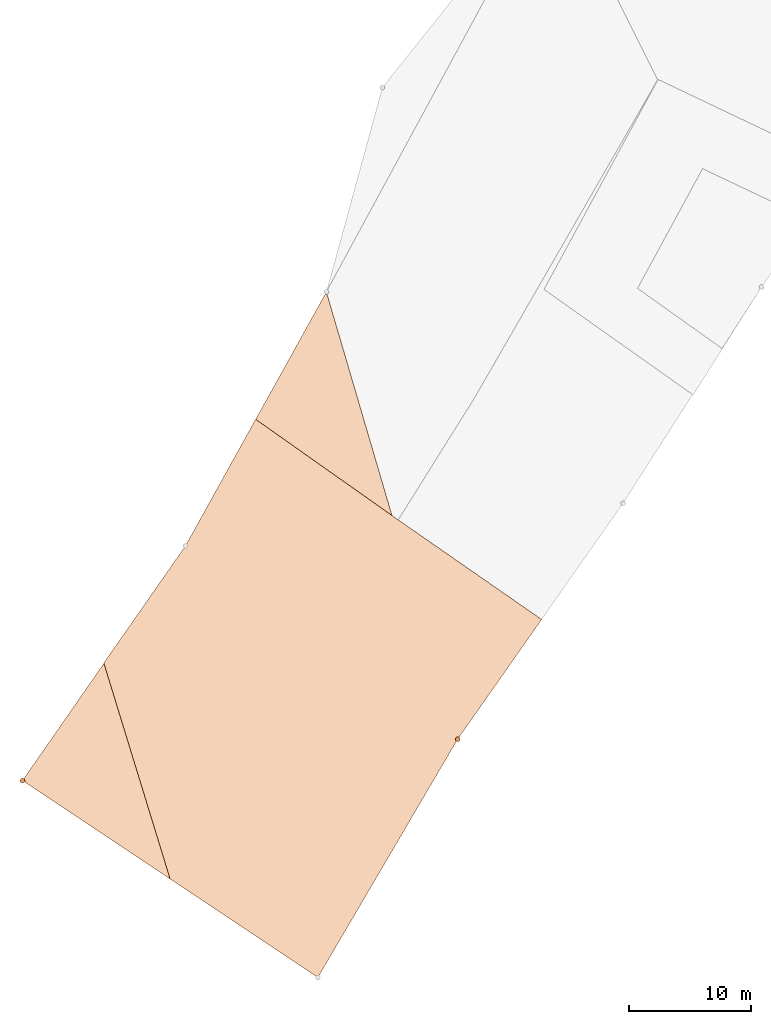
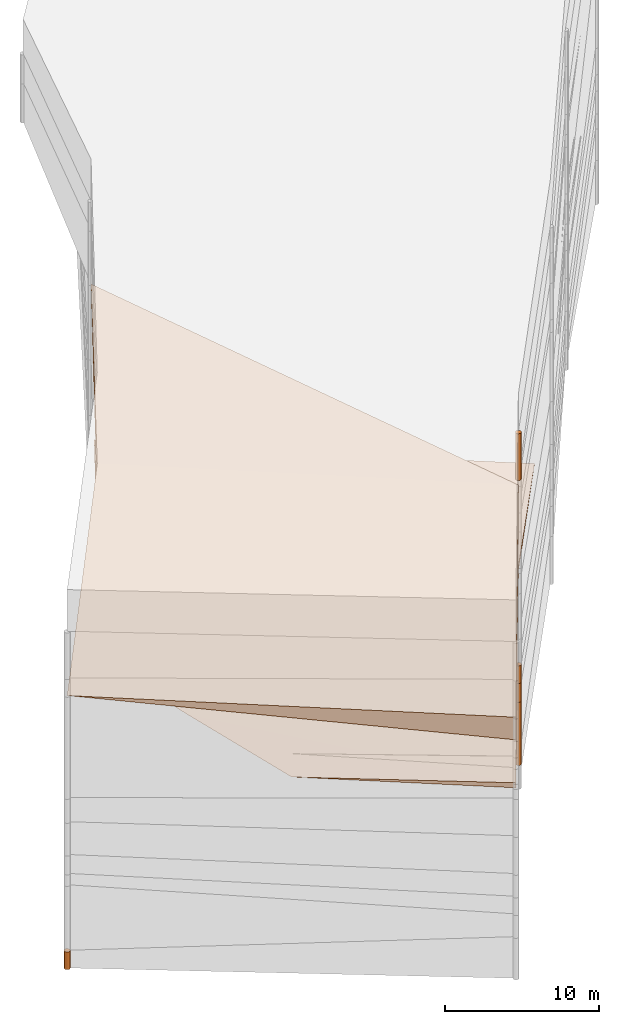
# One storey, part 5 of 24: 7 geographic elements.
"""IFC4 building model written with IfcOpenShell, lengths in metres."""

import ifcopenshell
import ifcopenshell.guid

model = None  # the IFC model being written
_history = None  # IfcOwnerHistory: only IFC2X3 demands one
_inside = {}  # id of a spatial element -> (the spatial element, [elements in it])
_under = {}  # id of a project, library or spatial element -> (it, [spatial elements below it])
_declared = {}  # id of a project -> (the project, [libraries it declares])
_typed = {}  # id of a type object -> (the type object, [elements of that type])
_made_of = {}  # id of a material, layer set ... -> (it, [elements and type objects made of it])


def new_model(schema):
    """Start an empty IFC model of exactly this schema.

    Asked for "IFC4X3", IfcOpenShell would pick the latest addendum, in which some entities
    have other attributes; the version numbers below select the first issue.
    IFC2X3 requires an IfcOwnerHistory on every rooted entity: one is made here for all.
    """
    global model, _history
    if schema == "IFC4X3":
        model = ifcopenshell.file(schema_version=(4, 3, 0, 0))
    else:
        model = ifcopenshell.file(schema=schema)
    _inside.clear()
    _under.clear()
    _declared.clear()
    _typed.clear()
    _made_of.clear()
    _history = None
    if model.schema == "IFC2X3":
        org = make("IfcOrganization", Name="unknown")
        user = make(
            "IfcPersonAndOrganization",
            ThePerson=make("IfcPerson", FamilyName="unknown"),
            TheOrganization=org,
        )
        app = make(
            "IfcApplication",
            ApplicationDeveloper=org,
            Version="unknown",
            ApplicationFullName="unknown",
            ApplicationIdentifier="unknown",
        )
        _history = make(
            "IfcOwnerHistory",
            OwningUser=user,
            OwningApplication=app,
            ChangeAction="ADDED",
            CreationDate=0,
        )
    return model


def make(cls, **values):
    """One entity of the class cls with the attributes given. An attribute that is None is left unset."""
    return model.create_entity(
        cls, **{name: value for name, value in values.items() if value is not None}
    )


def entity(cls, *values):
    """Any entity or typed value of the class cls, its attributes in the order of the schema. None: left unset."""
    e = model.create_entity(cls)
    for i, value in enumerate(values):
        if value is not None:
            e[i] = value
    return e


def rooted(cls, **values):
    """An entity with a GlobalId (a new one), such as an element, a storey or a relation."""
    return make(cls, GlobalId=ifcopenshell.guid.new(), OwnerHistory=_history, **values)


def si_unit(unit_type, name, prefix=None):
    """IfcSIUnit, for example si_unit("LENGTHUNIT", "METRE", prefix="MILLI")."""
    return make("IfcSIUnit", UnitType=unit_type, Prefix=prefix, Name=name)


def converted_unit(unit_type, name, factor, base, dimensions=None, offset=None):
    """IfcConversionBasedUnit, such as the inch: factor (a typed value) times the base unit."""
    return make(
        "IfcConversionBasedUnit"
        if offset is None
        else "IfcConversionBasedUnitWithOffset",
        ConversionOffset=offset,
        Dimensions=None
        if dimensions is None
        else entity("IfcDimensionalExponents", *dimensions),
        UnitType=unit_type,
        Name=name,
        ConversionFactor=make(
            "IfcMeasureWithUnit", ValueComponent=factor, UnitComponent=base
        ),
    )


def assignment(units):
    """IfcUnitAssignment: the units of a project."""
    return None if units is None else make("IfcUnitAssignment", Units=units)


def point(xyz):
    """IfcCartesianPoint."""
    return None if xyz is None else make("IfcCartesianPoint", Coordinates=xyz)


def direction(xyz):
    """IfcDirection."""
    return None if xyz is None else make("IfcDirection", DirectionRatios=xyz)


def frame(location, z_axis=None, x_axis=None):
    """IfcAxis2Placement3D, a coordinate frame: its origin and axes. An axis left out is left unset."""
    return make(
        "IfcAxis2Placement3D",
        Location=point(location),
        Axis=direction(z_axis),
        RefDirection=direction(x_axis),
    )


def frame_2d(location, x_axis=None):
    """IfcAxis2Placement2D, a coordinate frame in the plane: its origin and x axis."""
    return make(
        "IfcAxis2Placement2D", Location=point(location), RefDirection=direction(x_axis)
    )


def origin_with_axes():
    """The frame at (0, 0, 0) with the z axis (0, 0, 1) and the x axis (1, 0, 0) written out."""
    return frame((0.0, 0.0, 0.0), z_axis=(0.0, 0.0, 1.0), x_axis=(1.0, 0.0, 0.0))


def origin_2d_with_axis():
    """The frame at (0, 0) in the plane with the x axis (1, 0) written out."""
    return frame_2d((0.0, 0.0), x_axis=(1.0, 0.0))


def place(relative_to, where):
    """IfcLocalPlacement: puts the frame where relative to a parent placement (None: the world)."""
    return make(
        "IfcLocalPlacement", PlacementRelTo=relative_to, RelativePlacement=where
    )


def context(
    kind, dimensions, precision=None, world=None, true_north=None, identifier=None
):
    """IfcGeometricRepresentationContext, for example the 3D "Model" context."""
    return make(
        "IfcGeometricRepresentationContext",
        ContextIdentifier=identifier,
        ContextType=kind,
        CoordinateSpaceDimension=dimensions,
        Precision=precision,
        WorldCoordinateSystem=world,
        TrueNorth=true_north,
    )


def subcontext(parent, identifier, kind, view, scale=None):
    """IfcGeometricRepresentationSubContext, for example "Body" below "Model"."""
    return make(
        "IfcGeometricRepresentationSubContext",
        ContextIdentifier=identifier,
        ContextType=kind,
        ParentContext=parent,
        TargetScale=scale,
        TargetView=view,
    )


def project(units=None, contexts=None):
    """IfcProject with its units and contexts."""
    return rooted(
        "IfcProject",
        Name="project",
        RepresentationContexts=contexts,
        UnitsInContext=assignment(units),
    )


def spatial(cls, under=None, at=None, **own):
    """A site, building, storey or space (cls), placed at a placement, below another one or the project."""
    s = rooted(cls, ObjectPlacement=at, **own)
    if under is not None:
        _under.setdefault(under.id(), (under, []))[1].append(s)
    return s


def point_list(points):
    """IfcCartesianPointList2D or 3D."""
    cls = (
        "IfcCartesianPointList2D" if len(points[0]) == 2 else "IfcCartesianPointList3D"
    )
    return make(cls, CoordList=points)


def polygons(points, faces, closed=None, point_numbers=None):
    """IfcPolygonalFaceSet: a face is its outer loop, then its inner loops; points numbered from 1."""
    made = []
    for loops in faces:
        if len(loops) == 1:
            made.append(make("IfcIndexedPolygonalFace", CoordIndex=loops[0]))
        else:
            made.append(
                make(
                    "IfcIndexedPolygonalFaceWithVoids",
                    CoordIndex=loops[0],
                    InnerCoordIndices=loops[1:],
                )
            )
    return make(
        "IfcPolygonalFaceSet",
        Coordinates=point_list(points),
        Closed=closed,
        Faces=made,
        PnIndex=point_numbers,
    )


def shape(context_of_items, identifier, shape_type, items):
    """IfcShapeRepresentation: the items that make up one representation, for example the "Body"."""
    return make(
        "IfcShapeRepresentation",
        ContextOfItems=context_of_items,
        RepresentationIdentifier=identifier,
        RepresentationType=shape_type,
        Items=items,
    )


def made_of(thing, what):
    """Note that an element or type object is made of a material, layer set ...; save() writes the relation."""
    if what is not None:
        _made_of.setdefault(what.id(), (what, []))[1].append(thing)
    return thing


def element(
    cls,
    number,
    at=None,
    inside=None,
    cuts=None,
    type_object=None,
    material=None,
    context=None,
    identifier="Body",
    shape_type=None,
    held_by="IfcProductDefinitionShape",
    body=None,
    shapes=None,
    **own,
):
    """One element of the class cls, such as IfcWall. Its Tag is "e" and its number.

    at: its placement. inside: the storey or other place that contains it. cuts: it is an
    opening in that element (IfcRelVoidsElement). A single representation is given by context,
    identifier, shape_type and body (its items); several are given by shapes. held_by: the class
    of the entity that holds the representations. save() writes the other relations.
    """
    e = rooted(cls, Tag="e%d" % number, ObjectPlacement=at, **own)
    if body is not None:
        shapes = [shape(context, identifier, shape_type, body)]
    if shapes is not None:
        e.Representation = make(held_by, Representations=shapes)
    if inside is not None:
        _inside.setdefault(inside.id(), (inside, []))[1].append(e)
    if cuts is not None:
        rooted(
            "IfcRelVoidsElement", RelatingBuildingElement=cuts, RelatedOpeningElement=e
        )
    if type_object is not None:
        _typed.setdefault(type_object.id(), (type_object, []))[1].append(e)
    return made_of(e, material)


def aggregate(whole, parts):
    """IfcRelAggregates: a whole, such as a stair, and the parts it consists of."""
    return rooted("IfcRelAggregates", RelatingObject=whole, RelatedObjects=parts)


def save(model, path):
    """Write the relations noted so far, then the file.

    IfcRelAggregates (storeys below a building ...), IfcRelContainedInSpatialStructure (elements
    in a storey), IfcRelDefinesByType, IfcRelAssociatesMaterial and IfcRelDeclares: one each for
    every whole, place, type object, material and project.
    """
    for whole, parts in _under.values():
        aggregate(whole, parts)
    for where, things in _inside.values():
        rooted(
            "IfcRelContainedInSpatialStructure",
            RelatedElements=things,
            RelatingStructure=where,
        )
    for kind, things in _typed.values():
        rooted("IfcRelDefinesByType", RelatedObjects=things, RelatingType=kind)
    for what, things in _made_of.values():
        rooted("IfcRelAssociatesMaterial", RelatedObjects=things, RelatingMaterial=what)
    for by, libraries in _declared.values():
        rooted("IfcRelDeclares", RelatingContext=by, RelatedDefinitions=libraries)
    model.write(path)


model = new_model("IFC4")

# Units and contexts
model_context = context("Model", 3, precision=1e-05, world=origin_with_axes())
plan_context = context("Plan", 2, precision=1e-05, world=origin_2d_with_axis())
body_context = subcontext(model_context, "Body", "Model", "MODEL_VIEW")
ifc_project = project(units=[converted_unit("PLANEANGLEUNIT", "degree", entity("IfcReal", 0.0174532925199433), si_unit("PLANEANGLEUNIT", "RADIAN"), dimensions=[0, 0, 0, 0, 0, 0, 0]), si_unit("AREAUNIT", "SQUARE_METRE"), si_unit("VOLUMEUNIT", "CUBIC_METRE"), si_unit("LENGTHUNIT", "METRE")], contexts=[model_context, plan_context])

# Site, building, storey
site_placement = place(None, origin_with_axes())
site = spatial("IfcSite", under=ifc_project, at=site_placement)
building_placement = place(site_placement, origin_with_axes())
building = spatial("IfcBuilding", under=site, at=building_placement, Name="Building")
storey_placement = place(building_placement, origin_with_axes())
storey = spatial("IfcBuildingStorey", under=building, at=storey_placement, Name="Storey")

# Geographic elements
geographic_element_1_placement = place(storey_placement, frame((-2.0654125213623, 16.8077659606934, 12.5232429504395), z_axis=(0.0, 0.0, 1.0), x_axis=(0.813539034007344, -0.58151030957877, 0.0)))
element("IfcGeographicElement", 1, at=geographic_element_1_placement, inside=storey, PredefinedType="NOTDEFINED", context=body_context, shape_type="Tessellation", body=[
    polygons([(-20.7735157012939, 33.8179397583008, -3.01824259757996), (-18.0570030212402, 10.0694561004639, -4.22324371337891), (-18.0570049285889, 10.0694599151611, -0.523242890834808), (11.4541826248169, -12.4727153778076, -4.72324132919312), (9.41227912902832, 10.1600189208984, -0.423243492841721), (11.4541816711426, -12.4727153778076, -2.92324137687683), (-17.7352809906006, -13.4240798950195, -2.52324271202087)], [[[3, 1, 2]], [[5, 6, 4]], [[7, 4, 6]], [[2, 5, 7]], [[7, 6, 5]], [[1, 3, 5]], [[1, 5, 2]], [[7, 3, 2]], [[7, 5, 4]], [[3, 7, 5]]]),
])
geographic_element_2_placement = place(storey_placement, frame((-4.35113143920898, 15.1479167938232, 4.93172883987427), z_axis=(0.0, 0.0, 1.0), x_axis=(0.768162961571184, -0.640254374815344, 0.0)))
element("IfcGeographicElement", 2, at=geographic_element_2_placement, inside=storey, PredefinedType="NOTDEFINED", context=body_context, shape_type="Tessellation", body=[
    polygons([(-9.25384426116943, -5.33445310592651, -0.181728839874268), (-18.061107635498, 11.4407739639282, 0.16827104985714), (-18.061107635498, 11.4407739639282, 1.06827068328857), (9.32578659057617, 13.5686807632446, 0.268270462751389), (9.32578659057617, 13.5686807632446, 0.668270587921143), (13.0408973693848, -8.8502368927002, -0.931725978851318), (13.0408973693848, -8.8502368927002, -0.5317263007164), (-1.47834300994873, -10.4072074890137, -0.731728553771973), (-6.60297393798828, 24.2455081939697, 0.468271255493164), (8.32325649261475, 25.55983543396, 0.468271523714066), (-20.2963562011719, 23.1440601348877, 0.618271589279175), (-17.0553722381592, -0.243257105350494, 0.618271350860596)], [[[3, 2, 12]], [[7, 4, 5]], [[1, 5, 3]], [[7, 1, 8]], [[4, 1, 2]], [[3, 9, 11]], [[1, 6, 8]], [[6, 7, 8]], [[4, 9, 10]], [[5, 4, 10]], [[5, 9, 3]], [[9, 2, 11]], [[2, 3, 11]], [[1, 3, 12]], [[2, 1, 12]], [[7, 6, 4]], [[1, 7, 5]], [[4, 6, 1]], [[4, 2, 9]], [[5, 10, 9]]]),
])
geographic_element_3_placement = place(storey_placement, frame((11.5, 19.6000003814697, 14.4499998092651), z_axis=(0.0, 0.0, 1.0), x_axis=(1.0, 0.0, 0.0)))
element("IfcGeographicElement", 3, at=geographic_element_3_placement, inside=storey, PredefinedType="NOTDEFINED", context=body_context, shape_type="Tessellation", body=[
    polygons([(0.0, 0.0, -1.84999990463257), (0.0390180610120296, 0.196157038211823, -1.84999990463257), (0.0, 0.199999988079071, -1.84999990463257), (0.0, 0.0, 1.84999990463257), (0.0, 0.199999988079071, 1.84999990463257), (0.0390180610120296, 0.196157038211823, 1.84999990463257), (0.0765366926789284, 0.18477588891983, -1.84999990463257), (0.0765366926789284, 0.18477588891983, 1.84999990463257), (0.111114047467709, 0.166293919086456, -1.84999990463257), (0.111114047467709, 0.166293919086456, 1.84999990463257), (0.141421362757683, 0.141421362757683, -1.84999990463257), (0.141421362757683, 0.141421362757683, 1.84999990463257), (0.166293919086456, 0.111114047467709, -1.84999990463257), (0.166293919086456, 0.111114047467709, 1.84999990463257), (0.18477588891983, 0.0765366926789284, -1.84999990463257), (0.18477588891983, 0.0765366926789284, 1.84999990463257), (0.196157038211823, 0.0390180610120296, -1.84999990463257), (0.196157038211823, 0.0390180610120296, 1.84999990463257), (0.199999988079071, 0.0, -1.84999990463257), (0.199999988079071, 0.0, 1.84999990463257), (0.196157038211823, -0.0390180610120296, -1.84999990463257), (0.196157038211823, -0.0390180610120296, 1.84999990463257), (0.18477588891983, -0.0765366926789284, -1.84999990463257), (0.18477588891983, -0.0765366926789284, 1.84999990463257), (0.166293919086456, -0.111114047467709, -1.84999990463257), (0.166293919086456, -0.111114047467709, 1.84999990463257), (0.141421362757683, -0.141421362757683, -1.84999990463257), (0.141421362757683, -0.141421362757683, 1.84999990463257), (0.111114047467709, -0.166293919086456, -1.84999990463257), (0.111114047467709, -0.166293919086456, 1.84999990463257), (0.0765366926789284, -0.18477588891983, -1.84999990463257), (0.0765366926789284, -0.18477588891983, 1.84999990463257), (0.0390180610120296, -0.196157038211823, -1.84999990463257), (0.0390180610120296, -0.196157038211823, 1.84999990463257), (0.0, -0.199999988079071, -1.84999990463257), (0.0, -0.199999988079071, 1.84999990463257), (-0.0390180610120296, -0.196157038211823, -1.84999990463257), (-0.0390180610120296, -0.196157038211823, 1.84999990463257), (-0.0765366926789284, -0.18477588891983, -1.84999990463257), (-0.0765366926789284, -0.18477588891983, 1.84999990463257), (-0.111114047467709, -0.166293919086456, -1.84999990463257), (-0.111114047467709, -0.166293919086456, 1.84999990463257), (-0.141421362757683, -0.141421362757683, -1.84999990463257), (-0.141421362757683, -0.141421362757683, 1.84999990463257), (-0.166293919086456, -0.111114047467709, -1.84999990463257), (-0.166293919086456, -0.111114047467709, 1.84999990463257), (-0.18477588891983, -0.0765366926789284, -1.84999990463257), (-0.18477588891983, -0.0765366926789284, 1.84999990463257), (-0.196157038211823, -0.0390180610120296, -1.84999990463257), (-0.196157038211823, -0.0390180610120296, 1.84999990463257), (-0.199999988079071, 0.0, -1.84999990463257), (-0.199999988079071, 0.0, 1.84999990463257), (-0.196157038211823, 0.0390180610120296, -1.84999990463257), (-0.196157038211823, 0.0390180610120296, 1.84999990463257), (-0.18477588891983, 0.0765366926789284, -1.84999990463257), (-0.18477588891983, 0.0765366926789284, 1.84999990463257), (-0.166293919086456, 0.111114047467709, -1.84999990463257), (-0.166293919086456, 0.111114047467709, 1.84999990463257), (-0.141421362757683, 0.141421362757683, -1.84999990463257), (-0.141421362757683, 0.141421362757683, 1.84999990463257), (-0.111114047467709, 0.166293919086456, -1.84999990463257), (-0.111114047467709, 0.166293919086456, 1.84999990463257), (-0.0765366926789284, 0.18477588891983, -1.84999990463257), (-0.0765366926789284, 0.18477588891983, 1.84999990463257), (-0.0390180610120296, 0.196157038211823, -1.84999990463257), (-0.0390180610120296, 0.196157038211823, 1.84999990463257)], [[[3, 2, 1]], [[6, 5, 4]], [[62, 64, 63, 61]], [[2, 7, 1]], [[8, 6, 4]], [[30, 32, 31, 29]], [[7, 9, 1]], [[10, 8, 4]], [[10, 12, 11, 9]], [[9, 11, 1]], [[12, 10, 4]], [[11, 13, 1]], [[12, 4, 14]], [[66, 5, 3, 65]], [[1, 13, 15]], [[4, 16, 14]], [[42, 44, 43, 41]], [[1, 15, 17]], [[4, 18, 16]], [[48, 50, 49, 47]], [[1, 17, 19]], [[4, 20, 18]], [[16, 18, 17, 15]], [[1, 19, 21]], [[4, 22, 20]], [[50, 52, 51, 49]], [[1, 21, 23]], [[22, 4, 24]], [[54, 56, 55, 53]], [[1, 23, 25]], [[24, 4, 26]], [[56, 58, 57, 55]], [[27, 1, 25]], [[26, 4, 28]], [[58, 60, 59, 57]], [[1, 27, 29]], [[28, 4, 30]], [[60, 62, 61, 59]], [[1, 29, 31]], [[4, 32, 30]], [[64, 66, 65, 63]], [[1, 31, 33]], [[4, 34, 32]], [[6, 8, 7, 2]], [[1, 33, 35]], [[4, 36, 34]], [[8, 10, 9, 7]], [[1, 35, 37]], [[4, 38, 36]], [[32, 34, 33, 31]], [[1, 37, 39]], [[4, 40, 38]], [[36, 38, 37, 35]], [[1, 39, 41]], [[4, 42, 40]], [[46, 48, 47, 45]], [[43, 1, 41]], [[4, 44, 42]], [[34, 36, 35, 33]], [[45, 1, 43]], [[46, 44, 4]], [[14, 16, 15, 13]], [[47, 1, 45]], [[48, 46, 4]], [[44, 46, 45, 43]], [[49, 1, 47]], [[50, 48, 4]], [[40, 42, 41, 39]], [[49, 51, 1]], [[52, 50, 4]], [[18, 20, 19, 17]], [[51, 53, 1]], [[54, 52, 4]], [[20, 22, 21, 19]], [[53, 55, 1]], [[4, 56, 54]], [[52, 54, 53, 51]], [[55, 57, 1]], [[4, 58, 56]], [[22, 24, 23, 21]], [[57, 59, 1]], [[60, 58, 4]], [[24, 26, 25, 23]], [[59, 61, 1]], [[62, 60, 4]], [[26, 28, 27, 25]], [[61, 63, 1]], [[64, 62, 4]], [[28, 30, 29, 27]], [[63, 65, 1]], [[66, 64, 4]], [[5, 6, 2, 3]], [[65, 3, 1]], [[5, 66, 4]], [[38, 40, 39, 37]], [[12, 14, 13, 11]]]),
])
geographic_element_4_placement = place(storey_placement, frame((11.5, 19.6000003814697, -7.50000095367432), z_axis=(0.0, 0.0, 1.0), x_axis=(1.0, 0.0, 0.0)))
element("IfcGeographicElement", 4, at=geographic_element_4_placement, inside=storey, PredefinedType="NOTDEFINED", context=body_context, shape_type="Tessellation", body=[
    polygons([(0.0, 0.0, -2.49999976158142), (0.0390180610120296, 0.196157038211823, -2.49999976158142), (0.0, 0.199999988079071, -2.49999976158142), (0.0, 0.0, 2.49999976158142), (0.0, 0.199999988079071, 2.49999976158142), (0.0390180610120296, 0.196157038211823, 2.49999976158142), (0.0765366926789284, 0.18477588891983, -2.49999976158142), (0.0765366926789284, 0.18477588891983, 2.49999976158142), (0.111114047467709, 0.166293919086456, -2.49999976158142), (0.111114047467709, 0.166293919086456, 2.49999976158142), (0.141421362757683, 0.141421362757683, -2.49999976158142), (0.141421362757683, 0.141421362757683, 2.49999976158142), (0.166293919086456, 0.111114047467709, -2.49999976158142), (0.166293919086456, 0.111114047467709, 2.49999976158142), (0.18477588891983, 0.0765366926789284, -2.49999976158142), (0.18477588891983, 0.0765366926789284, 2.49999976158142), (0.196157038211823, 0.0390180610120296, -2.49999976158142), (0.196157038211823, 0.0390180610120296, 2.49999976158142), (0.199999988079071, 0.0, -2.49999976158142), (0.199999988079071, 0.0, 2.49999976158142), (0.196157038211823, -0.0390180610120296, -2.49999976158142), (0.196157038211823, -0.0390180610120296, 2.49999976158142), (0.18477588891983, -0.0765366926789284, -2.49999976158142), (0.18477588891983, -0.0765366926789284, 2.49999976158142), (0.166293919086456, -0.111114047467709, -2.49999976158142), (0.166293919086456, -0.111114047467709, 2.49999976158142), (0.141421362757683, -0.141421362757683, -2.49999976158142), (0.141421362757683, -0.141421362757683, 2.49999976158142), (0.111114047467709, -0.166293919086456, -2.49999976158142), (0.111114047467709, -0.166293919086456, 2.49999976158142), (0.0765366926789284, -0.18477588891983, -2.49999976158142), (0.0765366926789284, -0.18477588891983, 2.49999976158142), (0.0390180610120296, -0.196157038211823, -2.49999976158142), (0.0390180610120296, -0.196157038211823, 2.49999976158142), (0.0, -0.199999988079071, -2.49999976158142), (0.0, -0.199999988079071, 2.49999976158142), (-0.0390180610120296, -0.196157038211823, -2.49999976158142), (-0.0390180610120296, -0.196157038211823, 2.49999976158142), (-0.0765366926789284, -0.18477588891983, -2.49999976158142), (-0.0765366926789284, -0.18477588891983, 2.49999976158142), (-0.111114047467709, -0.166293919086456, -2.49999976158142), (-0.111114047467709, -0.166293919086456, 2.49999976158142), (-0.141421362757683, -0.141421362757683, -2.49999976158142), (-0.141421362757683, -0.141421362757683, 2.49999976158142), (-0.166293919086456, -0.111114047467709, -2.49999976158142), (-0.166293919086456, -0.111114047467709, 2.49999976158142), (-0.18477588891983, -0.0765366926789284, -2.49999976158142), (-0.18477588891983, -0.0765366926789284, 2.49999976158142), (-0.196157038211823, -0.0390180610120296, -2.49999976158142), (-0.196157038211823, -0.0390180610120296, 2.49999976158142), (-0.199999988079071, 0.0, -2.49999976158142), (-0.199999988079071, 0.0, 2.49999976158142), (-0.196157038211823, 0.0390180610120296, -2.49999976158142), (-0.196157038211823, 0.0390180610120296, 2.49999976158142), (-0.18477588891983, 0.0765366926789284, -2.49999976158142), (-0.18477588891983, 0.0765366926789284, 2.49999976158142), (-0.166293919086456, 0.111114047467709, -2.49999976158142), (-0.166293919086456, 0.111114047467709, 2.49999976158142), (-0.141421362757683, 0.141421362757683, -2.49999976158142), (-0.141421362757683, 0.141421362757683, 2.49999976158142), (-0.111114047467709, 0.166293919086456, -2.49999976158142), (-0.111114047467709, 0.166293919086456, 2.49999976158142), (-0.0765366926789284, 0.18477588891983, -2.49999976158142), (-0.0765366926789284, 0.18477588891983, 2.49999976158142), (-0.0390180610120296, 0.196157038211823, -2.49999976158142), (-0.0390180610120296, 0.196157038211823, 2.49999976158142)], [[[3, 2, 1]], [[6, 5, 4]], [[62, 64, 63, 61]], [[2, 7, 1]], [[8, 6, 4]], [[30, 32, 31, 29]], [[7, 9, 1]], [[10, 8, 4]], [[10, 12, 11, 9]], [[9, 11, 1]], [[12, 10, 4]], [[11, 13, 1]], [[12, 4, 14]], [[66, 5, 3, 65]], [[1, 13, 15]], [[4, 16, 14]], [[42, 44, 43, 41]], [[1, 15, 17]], [[16, 4, 18]], [[48, 50, 49, 47]], [[1, 17, 19]], [[4, 20, 18]], [[16, 18, 17, 15]], [[1, 19, 21]], [[4, 22, 20]], [[50, 52, 51, 49]], [[1, 21, 23]], [[22, 4, 24]], [[54, 56, 55, 53]], [[1, 23, 25]], [[4, 26, 24]], [[56, 58, 57, 55]], [[1, 25, 27]], [[26, 4, 28]], [[58, 60, 59, 57]], [[1, 27, 29]], [[28, 4, 30]], [[60, 62, 61, 59]], [[1, 29, 31]], [[4, 32, 30]], [[64, 66, 65, 63]], [[1, 31, 33]], [[4, 34, 32]], [[6, 8, 7, 2]], [[1, 33, 35]], [[4, 36, 34]], [[8, 10, 9, 7]], [[1, 35, 37]], [[4, 38, 36]], [[32, 34, 33, 31]], [[1, 37, 39]], [[4, 40, 38]], [[36, 38, 37, 35]], [[1, 39, 41]], [[4, 42, 40]], [[46, 48, 47, 45]], [[43, 1, 41]], [[4, 44, 42]], [[34, 36, 35, 33]], [[45, 1, 43]], [[4, 46, 44]], [[14, 16, 15, 13]], [[45, 47, 1]], [[48, 46, 4]], [[44, 46, 45, 43]], [[49, 1, 47]], [[4, 50, 48]], [[40, 42, 41, 39]], [[49, 51, 1]], [[52, 50, 4]], [[18, 20, 19, 17]], [[51, 53, 1]], [[54, 52, 4]], [[20, 22, 21, 19]], [[55, 1, 53]], [[4, 56, 54]], [[52, 54, 53, 51]], [[55, 57, 1]], [[58, 56, 4]], [[22, 24, 23, 21]], [[59, 1, 57]], [[60, 58, 4]], [[24, 26, 25, 23]], [[59, 61, 1]], [[62, 60, 4]], [[26, 28, 27, 25]], [[61, 63, 1]], [[64, 62, 4]], [[28, 30, 29, 27]], [[63, 65, 1]], [[66, 64, 4]], [[5, 6, 2, 3]], [[65, 3, 1]], [[5, 66, 4]], [[38, 40, 39, 37]], [[12, 14, 13, 11]]]),
])
geographic_element_5_placement = place(storey_placement, frame((11.5, 19.6000003814697, -4.25000095367432), z_axis=(0.0, 0.0, 1.0), x_axis=(1.0, 0.0, 0.0)))
element("IfcGeographicElement", 5, at=geographic_element_5_placement, inside=storey, PredefinedType="NOTDEFINED", context=body_context, shape_type="Tessellation", body=[
    polygons([(0.0, 0.0, -0.749999940395355), (0.0390180610120296, 0.196157038211823, -0.749999940395355), (0.0, 0.199999988079071, -0.749999940395355), (0.0, 0.0, 0.749999940395355), (0.0, 0.199999988079071, 0.749999940395355), (0.0390180610120296, 0.196157038211823, 0.749999940395355), (0.0765366926789284, 0.18477588891983, -0.749999940395355), (0.0765366926789284, 0.18477588891983, 0.749999940395355), (0.111114047467709, 0.166293919086456, -0.749999940395355), (0.111114047467709, 0.166293919086456, 0.749999940395355), (0.141421362757683, 0.141421362757683, -0.749999940395355), (0.141421362757683, 0.141421362757683, 0.749999940395355), (0.166293919086456, 0.111114047467709, -0.749999940395355), (0.166293919086456, 0.111114047467709, 0.749999940395355), (0.18477588891983, 0.0765366926789284, -0.749999940395355), (0.18477588891983, 0.0765366926789284, 0.749999940395355), (0.196157038211823, 0.0390180610120296, -0.749999940395355), (0.196157038211823, 0.0390180610120296, 0.749999940395355), (0.199999988079071, 0.0, -0.749999940395355), (0.199999988079071, 0.0, 0.749999940395355), (0.196157038211823, -0.0390180610120296, -0.749999940395355), (0.196157038211823, -0.0390180610120296, 0.749999940395355), (0.18477588891983, -0.0765366926789284, -0.749999940395355), (0.18477588891983, -0.0765366926789284, 0.749999940395355), (0.166293919086456, -0.111114047467709, -0.749999940395355), (0.166293919086456, -0.111114047467709, 0.749999940395355), (0.141421362757683, -0.141421362757683, -0.749999940395355), (0.141421362757683, -0.141421362757683, 0.749999940395355), (0.111114047467709, -0.166293919086456, -0.749999940395355), (0.111114047467709, -0.166293919086456, 0.749999940395355), (0.0765366926789284, -0.18477588891983, -0.749999940395355), (0.0765366926789284, -0.18477588891983, 0.749999940395355), (0.0390180610120296, -0.196157038211823, -0.749999940395355), (0.0390180610120296, -0.196157038211823, 0.749999940395355), (0.0, -0.199999988079071, -0.749999940395355), (0.0, -0.199999988079071, 0.749999940395355), (-0.0390180610120296, -0.196157038211823, -0.749999940395355), (-0.0390180610120296, -0.196157038211823, 0.749999940395355), (-0.0765366926789284, -0.18477588891983, -0.749999940395355), (-0.0765366926789284, -0.18477588891983, 0.749999940395355), (-0.111114047467709, -0.166293919086456, -0.749999940395355), (-0.111114047467709, -0.166293919086456, 0.749999940395355), (-0.141421362757683, -0.141421362757683, -0.749999940395355), (-0.141421362757683, -0.141421362757683, 0.749999940395355), (-0.166293919086456, -0.111114047467709, -0.749999940395355), (-0.166293919086456, -0.111114047467709, 0.749999940395355), (-0.18477588891983, -0.0765366926789284, -0.749999940395355), (-0.18477588891983, -0.0765366926789284, 0.749999940395355), (-0.196157038211823, -0.0390180610120296, -0.749999940395355), (-0.196157038211823, -0.0390180610120296, 0.749999940395355), (-0.199999988079071, 0.0, -0.749999940395355), (-0.199999988079071, 0.0, 0.749999940395355), (-0.196157038211823, 0.0390180610120296, -0.749999940395355), (-0.196157038211823, 0.0390180610120296, 0.749999940395355), (-0.18477588891983, 0.0765366926789284, -0.749999940395355), (-0.18477588891983, 0.0765366926789284, 0.749999940395355), (-0.166293919086456, 0.111114047467709, -0.749999940395355), (-0.166293919086456, 0.111114047467709, 0.749999940395355), (-0.141421362757683, 0.141421362757683, -0.749999940395355), (-0.141421362757683, 0.141421362757683, 0.749999940395355), (-0.111114047467709, 0.166293919086456, -0.749999940395355), (-0.111114047467709, 0.166293919086456, 0.749999940395355), (-0.0765366926789284, 0.18477588891983, -0.749999940395355), (-0.0765366926789284, 0.18477588891983, 0.749999940395355), (-0.0390180610120296, 0.196157038211823, -0.749999940395355), (-0.0390180610120296, 0.196157038211823, 0.749999940395355)], [[[3, 2, 1]], [[6, 5, 4]], [[28, 30, 29, 27]], [[2, 7, 1]], [[8, 6, 4]], [[36, 38, 37, 35]], [[7, 9, 1]], [[10, 8, 4]], [[56, 58, 57, 55]], [[9, 11, 1]], [[12, 10, 4]], [[58, 60, 59, 57]], [[11, 13, 1]], [[12, 4, 14]], [[54, 56, 55, 53]], [[1, 13, 15]], [[4, 16, 14]], [[10, 12, 11, 9]], [[1, 15, 17]], [[4, 18, 16]], [[60, 62, 61, 59]], [[1, 17, 19]], [[4, 20, 18]], [[16, 18, 17, 15]], [[1, 19, 21]], [[20, 4, 22]], [[18, 20, 19, 17]], [[1, 21, 23]], [[4, 24, 22]], [[20, 22, 21, 19]], [[1, 23, 25]], [[24, 4, 26]], [[22, 24, 23, 21]], [[1, 25, 27]], [[26, 4, 28]], [[24, 26, 25, 23]], [[1, 27, 29]], [[28, 4, 30]], [[62, 64, 63, 61]], [[1, 29, 31]], [[4, 32, 30]], [[64, 66, 65, 63]], [[1, 31, 33]], [[4, 34, 32]], [[30, 32, 31, 29]], [[1, 33, 35]], [[4, 36, 34]], [[8, 10, 9, 7]], [[1, 35, 37]], [[4, 38, 36]], [[32, 34, 33, 31]], [[1, 37, 39]], [[4, 40, 38]], [[6, 8, 7, 2]], [[1, 39, 41]], [[4, 42, 40]], [[38, 40, 39, 37]], [[43, 1, 41]], [[4, 44, 42]], [[40, 42, 41, 39]], [[45, 1, 43]], [[4, 46, 44]], [[42, 44, 43, 41]], [[47, 1, 45]], [[48, 46, 4]], [[44, 46, 45, 43]], [[47, 49, 1]], [[50, 48, 4]], [[46, 48, 47, 45]], [[51, 1, 49]], [[52, 50, 4]], [[48, 50, 49, 47]], [[51, 53, 1]], [[4, 54, 52]], [[66, 5, 3, 65]], [[53, 55, 1]], [[56, 54, 4]], [[52, 54, 53, 51]], [[55, 57, 1]], [[4, 58, 56]], [[59, 1, 57]], [[60, 58, 4]], [[34, 36, 35, 33]], [[59, 61, 1]], [[62, 60, 4]], [[14, 16, 15, 13]], [[61, 63, 1]], [[64, 62, 4]], [[26, 28, 27, 25]], [[63, 65, 1]], [[66, 64, 4]], [[5, 6, 2, 3]], [[65, 3, 1]], [[5, 66, 4]], [[50, 52, 51, 49]], [[12, 14, 13, 11]]]),
])
geographic_element_6_placement = place(storey_placement, frame((11.5, 19.6000003814697, -2.8000009059906), z_axis=(0.0, 0.0, 1.0), x_axis=(1.0, 0.0, 0.0)))
element("IfcGeographicElement", 6, at=geographic_element_6_placement, inside=storey, PredefinedType="NOTDEFINED", context=body_context, shape_type="Tessellation", body=[
    polygons([(0.0, 0.0, -0.699999928474426), (0.0390180610120296, 0.196157038211823, -0.699999928474426), (0.0, 0.199999988079071, -0.699999928474426), (0.0, 0.0, 0.699999928474426), (0.0, 0.199999988079071, 0.699999928474426), (0.0390180610120296, 0.196157038211823, 0.699999928474426), (0.0765366926789284, 0.18477588891983, -0.699999928474426), (0.0765366926789284, 0.18477588891983, 0.699999928474426), (0.111114047467709, 0.166293919086456, -0.699999928474426), (0.111114047467709, 0.166293919086456, 0.699999928474426), (0.141421362757683, 0.141421362757683, -0.699999928474426), (0.141421362757683, 0.141421362757683, 0.699999928474426), (0.166293919086456, 0.111114047467709, -0.699999928474426), (0.166293919086456, 0.111114047467709, 0.699999928474426), (0.18477588891983, 0.0765366926789284, -0.699999928474426), (0.18477588891983, 0.0765366926789284, 0.699999928474426), (0.196157038211823, 0.0390180610120296, -0.699999928474426), (0.196157038211823, 0.0390180610120296, 0.699999928474426), (0.199999988079071, 0.0, -0.699999928474426), (0.199999988079071, 0.0, 0.699999928474426), (0.196157038211823, -0.0390180610120296, -0.699999928474426), (0.196157038211823, -0.0390180610120296, 0.699999928474426), (0.18477588891983, -0.0765366926789284, -0.699999928474426), (0.18477588891983, -0.0765366926789284, 0.699999928474426), (0.166293919086456, -0.111114047467709, -0.699999928474426), (0.166293919086456, -0.111114047467709, 0.699999928474426), (0.141421362757683, -0.141421362757683, -0.699999928474426), (0.141421362757683, -0.141421362757683, 0.699999928474426), (0.111114047467709, -0.166293919086456, -0.699999928474426), (0.111114047467709, -0.166293919086456, 0.699999928474426), (0.0765366926789284, -0.18477588891983, -0.699999928474426), (0.0765366926789284, -0.18477588891983, 0.699999928474426), (0.0390180610120296, -0.196157038211823, -0.699999928474426), (0.0390180610120296, -0.196157038211823, 0.699999928474426), (0.0, -0.199999988079071, -0.699999928474426), (0.0, -0.199999988079071, 0.699999928474426), (-0.0390180610120296, -0.196157038211823, -0.699999928474426), (-0.0390180610120296, -0.196157038211823, 0.699999928474426), (-0.0765366926789284, -0.18477588891983, -0.699999928474426), (-0.0765366926789284, -0.18477588891983, 0.699999928474426), (-0.111114047467709, -0.166293919086456, -0.699999928474426), (-0.111114047467709, -0.166293919086456, 0.699999928474426), (-0.141421362757683, -0.141421362757683, -0.699999928474426), (-0.141421362757683, -0.141421362757683, 0.699999928474426), (-0.166293919086456, -0.111114047467709, -0.699999928474426), (-0.166293919086456, -0.111114047467709, 0.699999928474426), (-0.18477588891983, -0.0765366926789284, -0.699999928474426), (-0.18477588891983, -0.0765366926789284, 0.699999928474426), (-0.196157038211823, -0.0390180610120296, -0.699999928474426), (-0.196157038211823, -0.0390180610120296, 0.699999928474426), (-0.199999988079071, 0.0, -0.699999928474426), (-0.199999988079071, 0.0, 0.699999928474426), (-0.196157038211823, 0.0390180610120296, -0.699999928474426), (-0.196157038211823, 0.0390180610120296, 0.699999928474426), (-0.18477588891983, 0.0765366926789284, -0.699999928474426), (-0.18477588891983, 0.0765366926789284, 0.699999928474426), (-0.166293919086456, 0.111114047467709, -0.699999928474426), (-0.166293919086456, 0.111114047467709, 0.699999928474426), (-0.141421362757683, 0.141421362757683, -0.699999928474426), (-0.141421362757683, 0.141421362757683, 0.699999928474426), (-0.111114047467709, 0.166293919086456, -0.699999928474426), (-0.111114047467709, 0.166293919086456, 0.699999928474426), (-0.0765366926789284, 0.18477588891983, -0.699999928474426), (-0.0765366926789284, 0.18477588891983, 0.699999928474426), (-0.0390180610120296, 0.196157038211823, -0.699999928474426), (-0.0390180610120296, 0.196157038211823, 0.699999928474426)], [[[3, 2, 1]], [[6, 5, 4]], [[28, 30, 29, 27]], [[2, 7, 1]], [[8, 6, 4]], [[36, 38, 37, 35]], [[7, 9, 1]], [[10, 8, 4]], [[56, 58, 57, 55]], [[9, 11, 1]], [[12, 10, 4]], [[58, 60, 59, 57]], [[11, 13, 1]], [[12, 4, 14]], [[54, 56, 55, 53]], [[1, 13, 15]], [[4, 16, 14]], [[10, 12, 11, 9]], [[1, 15, 17]], [[4, 18, 16]], [[60, 62, 61, 59]], [[1, 17, 19]], [[4, 20, 18]], [[16, 18, 17, 15]], [[1, 19, 21]], [[4, 22, 20]], [[18, 20, 19, 17]], [[1, 21, 23]], [[4, 24, 22]], [[20, 22, 21, 19]], [[1, 23, 25]], [[4, 26, 24]], [[22, 24, 23, 21]], [[27, 1, 25]], [[26, 4, 28]], [[24, 26, 25, 23]], [[1, 27, 29]], [[28, 4, 30]], [[62, 64, 63, 61]], [[1, 29, 31]], [[4, 32, 30]], [[64, 66, 65, 63]], [[1, 31, 33]], [[4, 34, 32]], [[30, 32, 31, 29]], [[1, 33, 35]], [[4, 36, 34]], [[8, 10, 9, 7]], [[1, 35, 37]], [[4, 38, 36]], [[32, 34, 33, 31]], [[1, 37, 39]], [[4, 40, 38]], [[6, 8, 7, 2]], [[1, 39, 41]], [[4, 42, 40]], [[38, 40, 39, 37]], [[43, 1, 41]], [[4, 44, 42]], [[40, 42, 41, 39]], [[45, 1, 43]], [[46, 44, 4]], [[42, 44, 43, 41]], [[45, 47, 1]], [[48, 46, 4]], [[44, 46, 45, 43]], [[47, 49, 1]], [[50, 48, 4]], [[46, 48, 47, 45]], [[49, 51, 1]], [[52, 50, 4]], [[48, 50, 49, 47]], [[51, 53, 1]], [[54, 52, 4]], [[66, 5, 3, 65]], [[53, 55, 1]], [[56, 54, 4]], [[52, 54, 53, 51]], [[55, 57, 1]], [[58, 56, 4]], [[57, 59, 1]], [[60, 58, 4]], [[34, 36, 35, 33]], [[59, 61, 1]], [[62, 60, 4]], [[14, 16, 15, 13]], [[61, 63, 1]], [[64, 62, 4]], [[26, 28, 27, 25]], [[63, 65, 1]], [[66, 64, 4]], [[5, 6, 2, 3]], [[65, 3, 1]], [[5, 66, 4]], [[50, 52, 51, 49]], [[12, 14, 13, 11]]]),
])
geographic_element_7_placement = place(storey_placement, frame((-24.2999992370605, 16.2000007629395, -10.8999996185303), z_axis=(0.0, 0.0, 1.0), x_axis=(1.0, 0.0, 0.0)))
element("IfcGeographicElement", 7, at=geographic_element_7_placement, inside=storey, PredefinedType="NOTDEFINED", context=body_context, shape_type="Tessellation", body=[
    polygons([(0.0, 0.0, -0.699999928474426), (0.0390180610120296, 0.196157038211823, -0.699999928474426), (0.0, 0.199999988079071, -0.699999928474426), (0.0, 0.0, 0.699999928474426), (0.0, 0.199999988079071, 0.699999928474426), (0.0390180610120296, 0.196157038211823, 0.699999928474426), (0.0765366926789284, 0.18477588891983, -0.699999928474426), (0.0765366926789284, 0.18477588891983, 0.699999928474426), (0.111114047467709, 0.166293919086456, -0.699999928474426), (0.111114047467709, 0.166293919086456, 0.699999928474426), (0.141421362757683, 0.141421362757683, -0.699999928474426), (0.141421362757683, 0.141421362757683, 0.699999928474426), (0.166293919086456, 0.111114047467709, -0.699999928474426), (0.166293919086456, 0.111114047467709, 0.699999928474426), (0.18477588891983, 0.0765366926789284, -0.699999928474426), (0.18477588891983, 0.0765366926789284, 0.699999928474426), (0.196157038211823, 0.0390180610120296, -0.699999928474426), (0.196157038211823, 0.0390180610120296, 0.699999928474426), (0.199999988079071, 0.0, -0.699999928474426), (0.199999988079071, 0.0, 0.699999928474426), (0.196157038211823, -0.0390180610120296, -0.699999928474426), (0.196157038211823, -0.0390180610120296, 0.699999928474426), (0.18477588891983, -0.0765366926789284, -0.699999928474426), (0.18477588891983, -0.0765366926789284, 0.699999928474426), (0.166293919086456, -0.111114047467709, -0.699999928474426), (0.166293919086456, -0.111114047467709, 0.699999928474426), (0.141421362757683, -0.141421362757683, -0.699999928474426), (0.141421362757683, -0.141421362757683, 0.699999928474426), (0.111114047467709, -0.166293919086456, -0.699999928474426), (0.111114047467709, -0.166293919086456, 0.699999928474426), (0.0765366926789284, -0.18477588891983, -0.699999928474426), (0.0765366926789284, -0.18477588891983, 0.699999928474426), (0.0390180610120296, -0.196157038211823, -0.699999928474426), (0.0390180610120296, -0.196157038211823, 0.699999928474426), (0.0, -0.199999988079071, -0.699999928474426), (0.0, -0.199999988079071, 0.699999928474426), (-0.0390180610120296, -0.196157038211823, -0.699999928474426), (-0.0390180610120296, -0.196157038211823, 0.699999928474426), (-0.0765366926789284, -0.18477588891983, -0.699999928474426), (-0.0765366926789284, -0.18477588891983, 0.699999928474426), (-0.111114047467709, -0.166293919086456, -0.699999928474426), (-0.111114047467709, -0.166293919086456, 0.699999928474426), (-0.141421362757683, -0.141421362757683, -0.699999928474426), (-0.141421362757683, -0.141421362757683, 0.699999928474426), (-0.166293919086456, -0.111114047467709, -0.699999928474426), (-0.166293919086456, -0.111114047467709, 0.699999928474426), (-0.18477588891983, -0.0765366926789284, -0.699999928474426), (-0.18477588891983, -0.0765366926789284, 0.699999928474426), (-0.196157038211823, -0.0390180610120296, -0.699999928474426), (-0.196157038211823, -0.0390180610120296, 0.699999928474426), (-0.199999988079071, 0.0, -0.699999928474426), (-0.199999988079071, 0.0, 0.699999928474426), (-0.196157038211823, 0.0390180610120296, -0.699999928474426), (-0.196157038211823, 0.0390180610120296, 0.699999928474426), (-0.18477588891983, 0.0765366926789284, -0.699999928474426), (-0.18477588891983, 0.0765366926789284, 0.699999928474426), (-0.166293919086456, 0.111114047467709, -0.699999928474426), (-0.166293919086456, 0.111114047467709, 0.699999928474426), (-0.141421362757683, 0.141421362757683, -0.699999928474426), (-0.141421362757683, 0.141421362757683, 0.699999928474426), (-0.111114047467709, 0.166293919086456, -0.699999928474426), (-0.111114047467709, 0.166293919086456, 0.699999928474426), (-0.0765366926789284, 0.18477588891983, -0.699999928474426), (-0.0765366926789284, 0.18477588891983, 0.699999928474426), (-0.0390180610120296, 0.196157038211823, -0.699999928474426), (-0.0390180610120296, 0.196157038211823, 0.699999928474426)], [[[3, 2, 1]], [[6, 5, 4]], [[28, 30, 29, 27]], [[2, 7, 1]], [[8, 6, 4]], [[36, 38, 37, 35]], [[7, 9, 1]], [[10, 8, 4]], [[56, 58, 57, 55]], [[9, 11, 1]], [[12, 10, 4]], [[58, 60, 59, 57]], [[11, 13, 1]], [[12, 4, 14]], [[54, 56, 55, 53]], [[1, 13, 15]], [[4, 16, 14]], [[10, 12, 11, 9]], [[1, 15, 17]], [[4, 18, 16]], [[60, 62, 61, 59]], [[1, 17, 19]], [[4, 20, 18]], [[16, 18, 17, 15]], [[1, 19, 21]], [[4, 22, 20]], [[18, 20, 19, 17]], [[1, 21, 23]], [[4, 24, 22]], [[20, 22, 21, 19]], [[1, 23, 25]], [[4, 26, 24]], [[22, 24, 23, 21]], [[27, 1, 25]], [[26, 4, 28]], [[24, 26, 25, 23]], [[1, 27, 29]], [[28, 4, 30]], [[62, 64, 63, 61]], [[1, 29, 31]], [[4, 32, 30]], [[64, 66, 65, 63]], [[1, 31, 33]], [[4, 34, 32]], [[30, 32, 31, 29]], [[1, 33, 35]], [[4, 36, 34]], [[8, 10, 9, 7]], [[1, 35, 37]], [[4, 38, 36]], [[32, 34, 33, 31]], [[1, 37, 39]], [[4, 40, 38]], [[6, 8, 7, 2]], [[1, 39, 41]], [[4, 42, 40]], [[38, 40, 39, 37]], [[43, 1, 41]], [[4, 44, 42]], [[40, 42, 41, 39]], [[45, 1, 43]], [[46, 44, 4]], [[42, 44, 43, 41]], [[45, 47, 1]], [[48, 46, 4]], [[44, 46, 45, 43]], [[47, 49, 1]], [[50, 48, 4]], [[46, 48, 47, 45]], [[49, 51, 1]], [[52, 50, 4]], [[48, 50, 49, 47]], [[51, 53, 1]], [[54, 52, 4]], [[66, 5, 3, 65]], [[53, 55, 1]], [[56, 54, 4]], [[52, 54, 53, 51]], [[55, 57, 1]], [[58, 56, 4]], [[57, 59, 1]], [[60, 58, 4]], [[34, 36, 35, 33]], [[59, 61, 1]], [[62, 60, 4]], [[14, 16, 15, 13]], [[61, 63, 1]], [[64, 62, 4]], [[26, 28, 27, 25]], [[63, 65, 1]], [[66, 64, 4]], [[5, 6, 2, 3]], [[65, 3, 1]], [[5, 66, 4]], [[50, 52, 51, 49]], [[12, 14, 13, 11]]]),
])

save(model, "model.ifc")
